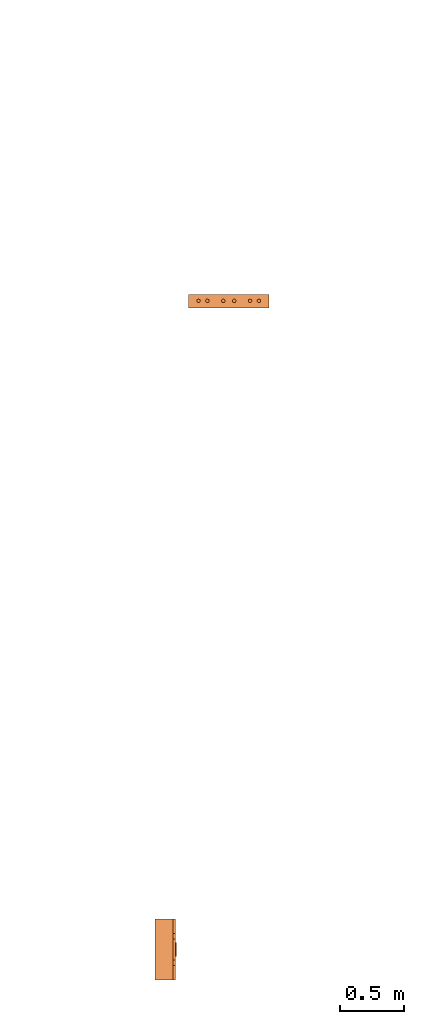
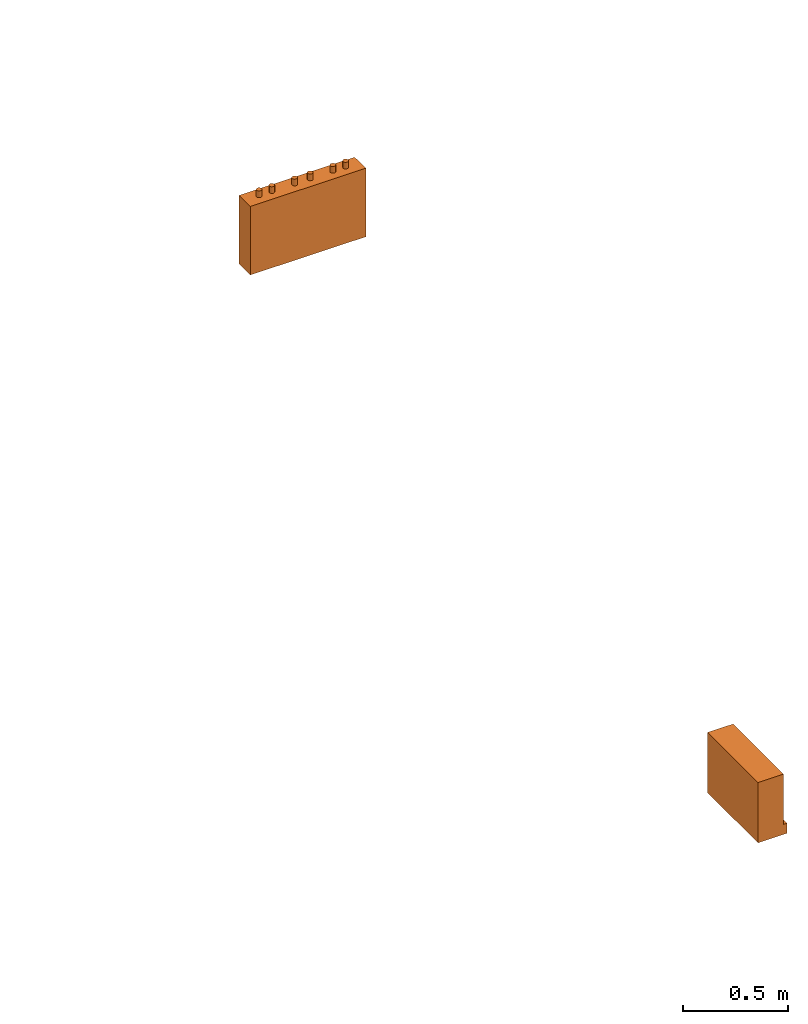
# One storey, part 2 of 4: 2 proxies.
"""IFC2X3 building model written with IfcOpenShell, lengths in millimetres."""

from ifc_helpers import new_model, entity, si_unit, converted_unit, derived_unit, direction, frame, origin, place, context, subcontext, project, spatial, faceted_brep, source, transform, mapped, material, material_list, type_object, type_shapes, element, save


model = new_model("IFC2X3")

# Units and contexts
model_context = context("Model", 3, precision=0.01, world=origin(), true_north=direction((6.12303176911189e-17, 1.0)))
body_context = subcontext(model_context, "Body", "Model", "MODEL_VIEW")
ifc_project = project(units=[si_unit("LENGTHUNIT", "METRE", prefix="MILLI"), si_unit("AREAUNIT", "SQUARE_METRE"), si_unit("VOLUMEUNIT", "CUBIC_METRE"), converted_unit("PLANEANGLEUNIT", "DEGREE", entity("IfcRatioMeasure", 0.0174532925199433), si_unit("PLANEANGLEUNIT", "RADIAN"), dimensions=[0, 0, 0, 0, 0, 0, 0]), si_unit("MASSUNIT", "GRAM", prefix="KILO"), derived_unit("MASSDENSITYUNIT", [(si_unit("MASSUNIT", "GRAM", prefix="KILO"), 1), (si_unit("LENGTHUNIT", "METRE"), -3)]), derived_unit("MOMENTOFINERTIAUNIT", [(si_unit("LENGTHUNIT", "METRE"), 4)]), si_unit("TIMEUNIT", "SECOND"), si_unit("FREQUENCYUNIT", "HERTZ"), si_unit("THERMODYNAMICTEMPERATUREUNIT", "DEGREE_CELSIUS"), derived_unit("THERMALTRANSMITTANCEUNIT", [(si_unit("MASSUNIT", "GRAM", prefix="KILO"), 1), (si_unit("THERMODYNAMICTEMPERATUREUNIT", "KELVIN"), -1), (si_unit("TIMEUNIT", "SECOND"), -3)]), derived_unit("VOLUMETRICFLOWRATEUNIT", [(si_unit("LENGTHUNIT", "METRE"), 3), (si_unit("TIMEUNIT", "SECOND"), -1)]), derived_unit("MASSFLOWRATEUNIT", [(si_unit("MASSUNIT", "GRAM", prefix="KILO"), 1), (si_unit("TIMEUNIT", "SECOND"), -1)]), derived_unit("ROTATIONALFREQUENCYUNIT", [(si_unit("TIMEUNIT", "SECOND"), -1)]), si_unit("ELECTRICCURRENTUNIT", "AMPERE"), si_unit("ELECTRICVOLTAGEUNIT", "VOLT"), si_unit("POWERUNIT", "WATT"), si_unit("FORCEUNIT", "NEWTON", prefix="KILO"), si_unit("ILLUMINANCEUNIT", "LUX"), si_unit("LUMINOUSFLUXUNIT", "LUMEN"), si_unit("LUMINOUSINTENSITYUNIT", "CANDELA"), derived_unit("USERDEFINED", [(si_unit("MASSUNIT", "GRAM", prefix="KILO"), -1), (si_unit("LENGTHUNIT", "METRE"), -2), (si_unit("TIMEUNIT", "SECOND"), 3), (si_unit("LUMINOUSFLUXUNIT", "LUMEN"), 1)]), derived_unit("LINEARVELOCITYUNIT", [(si_unit("LENGTHUNIT", "METRE"), 1), (si_unit("TIMEUNIT", "SECOND"), -1)]), si_unit("PRESSUREUNIT", "PASCAL"), derived_unit("USERDEFINED", [(si_unit("LENGTHUNIT", "METRE"), -2), (si_unit("MASSUNIT", "GRAM", prefix="KILO"), 1), (si_unit("TIMEUNIT", "SECOND"), -2)]), derived_unit("LINEARFORCEUNIT", [(si_unit("MASSUNIT", "GRAM", prefix="KILO"), 1), (si_unit("LENGTHUNIT", "METRE"), 1), (si_unit("TIMEUNIT", "SECOND"), -2), (si_unit("LENGTHUNIT", "METRE"), -1)]), derived_unit("PLANARFORCEUNIT", [(si_unit("MASSUNIT", "GRAM", prefix="KILO"), 1), (si_unit("LENGTHUNIT", "METRE"), 1), (si_unit("TIMEUNIT", "SECOND"), -2), (si_unit("LENGTHUNIT", "METRE"), -2)])], contexts=[model_context])

# Site, building, storey
site_placement = place(None, frame((0.0, 2493.83037508239, 0.0)))
site = spatial("IfcSite", under=ifc_project, at=site_placement, CompositionType="ELEMENT")
building_placement = place(site_placement, origin())
building = spatial("IfcBuilding", under=site, at=building_placement, CompositionType="ELEMENT")
storey_placement = place(building_placement, frame((0.0, 0.0, 15900.0)))
storey = spatial("IfcBuildingStorey", under=building, at=storey_placement, Name="05", CompositionType="ELEMENT", Elevation=15900.0)

# Proxies
ifc_material_1 = material()
ifc_material_2 = material()
ifc_material_list_1 = material_list([ifc_material_1, ifc_material_2])
building_element_proxy_type_1 = type_object("IfcBuildingElementProxyType", PredefinedType="NOTDEFINED", material=ifc_material_1)
shared_shape_1 = source(origin(), body_context, "Body", "Brep", [
    faceted_brep([(168.201612490282, 212.500000000001, 135.54049916809), (168.201612490282, 201.109127034741, 126.799974925206), (168.201612490282, 192.368602791857, 115.409101959946), (168.201612490282, 186.874079554102, 102.144149440585), (168.201612490282, 185.0, 87.9091019599461), (168.201612490282, 186.874079554102, 73.6740544793074), (168.201612490282, 192.368602791856, 60.4091019599461), (168.201612490282, 201.10912703474, 49.0182289946861), (168.201612490282, 212.500000000001, 40.2777047518019), (168.201612490282, 225.764952519362, 34.7831815140474), (168.201612490282, 240.0, 32.9091019599461), (168.201612490282, 254.235047480639, 34.7831815140472), (168.201612490282, 267.5, 40.2777047518019), (168.201612490282, 278.890872965261, 49.0182289946858), (168.201612490282, 287.631397208145, 60.4091019599458), (168.201612490282, 293.125920445899, 73.6740544793071), (168.201612490282, 295.0, 87.9091019599458), (168.201612490282, 293.125920445899, 102.144149440584), (168.201612490282, 287.631397208145, 115.409101959946), (168.201612490282, 278.890872965261, 126.799974925206), (168.201612490282, 267.500000000001, 135.54049916809), (168.201612490282, 254.235047480639, 141.035022405845), (168.201612490282, 240.0, 142.909101959946), (168.201612490282, 225.764952519362, 141.035022405845), (160.0, 225.764952519362, 34.7831815140474), (160.0, 212.500000000001, 40.2777047518019), (160.0, 201.10912703474, 49.0182289946861), (160.0, 192.368602791856, 60.4091019599461), (160.0, 186.874079554102, 73.6740544793074), (160.0, 185.0, 87.9091019599463), (160.0, 186.874079554102, 102.144149440585), (160.0, 192.368602791857, 115.409101959946), (160.0, 201.109127034741, 126.799974925206), (160.0, 212.500000000001, 135.54049916809), (160.0, 225.764952519362, 141.035022405845), (160.0, 240.0, 142.909101959946), (160.0, 254.235047480639, 141.035022405845), (160.0, 267.500000000001, 135.54049916809), (160.0, 278.890872965261, 126.799974925206), (160.0, 287.631397208145, 115.409101959946), (160.0, 293.125920445899, 102.144149440584), (160.0, 295.0, 87.9091019599458), (160.0, 293.125920445899, 73.6740544793071), (160.0, 287.631397208145, 60.4091019599458), (160.0, 278.890872965261, 49.0182289946858), (160.0, 267.5, 40.2777047518019), (160.0, 254.235047480639, 34.7831815140472), (160.0, 240.0, 32.9091019599461)], [[[0, 1, 2, 3, 4, 5, 6, 7, 8, 9, 10, 11, 12, 13, 14, 15, 16, 17, 18, 19, 20, 21, 22, 23]], [[24, 25, 26, 27, 28, 29, 30, 31, 32, 33, 34, 35, 36, 37, 38, 39, 40, 41, 42, 43, 44, 45, 46, 47]], [[40, 17, 16, 41]], [[39, 18, 17, 40]], [[20, 19, 38, 37]], [[39, 38, 19, 18]], [[21, 20, 37, 36]], [[22, 21, 36, 35]], [[34, 23, 22, 35]], [[33, 0, 23, 34]], [[2, 1, 32, 31]], [[33, 32, 1, 0]], [[3, 2, 31, 30]], [[4, 3, 30, 29]], [[28, 5, 4, 29]], [[27, 6, 5, 28]], [[8, 7, 26, 25]], [[27, 26, 7, 6]], [[9, 8, 25, 24]], [[10, 9, 24, 47]], [[46, 11, 10, 47]], [[45, 12, 11, 46]], [[14, 13, 44, 43]], [[45, 44, 13, 12]], [[15, 14, 43, 42]], [[16, 15, 42, 41]]]),
    faceted_brep([(160.0, 0.0, 0.0), (160.0, 480.0, 0.0), (160.0, 480.0, 58.2870579365997), (160.0, 365.0, 58.2870579366005), (160.0, 322.247482084292, 175.748635534839), (160.0, 157.75251791571, 175.748635534839), (160.0, 115.0, 58.2870579366), (160.0, 0.0, 58.2870579365997), (0.0, 480.0, 0.0), (0.0, 0.0, 0.0), (0.0, 0.0, 350.0), (0.0, 480.0, 350.0), (140.211167148102, 480.0, 350.0), (140.211167148102, 480.0, 58.2870579365997), (140.211167148102, 0.0, 350.0), (140.211167148102, 0.0, 58.2870579365997), (140.211167148102, 365.0, 58.2870579366), (140.211167148102, 115.0, 58.2870579366), (140.211167148102, 157.75251791571, 175.748635534839), (140.211167148102, 322.247482084292, 175.748635534839)], [[[0, 1, 2, 3, 4, 5, 6, 7]], [[8, 9, 10, 11]], [[8, 11, 12, 13, 2, 1]], [[11, 10, 14, 12]], [[10, 9, 0, 7, 15, 14]], [[1, 0, 9, 8]], [[16, 13, 12, 14, 15, 17, 18, 19]], [[13, 16, 3, 2]], [[17, 15, 7, 6]], [[18, 17, 6, 5]], [[19, 18, 5, 4]], [[16, 19, 4, 3]]]),
])
type_shapes(building_element_proxy_type_1, [shared_shape_1])
proxy_1_placement = place(storey_placement, frame((62632.608534949, 530.028144146123, 1500.0)))
element("IfcBuildingElementProxy", 1, at=proxy_1_placement, inside=storey, type_object=building_element_proxy_type_1, material=ifc_material_list_1, context=body_context, shape_type="MappedRepresentation", body=[
    mapped(shared_shape_1, transform((0.0, 0.0, 0.0), scale=1.0)),
])
ifc_material_3 = material()
ifc_material_list_2 = material_list([ifc_material_3, ifc_material_2])
building_element_proxy_type_2 = type_object("IfcBuildingElementProxyType", PredefinedType="NOTDEFINED", material=ifc_material_3)
shared_shape_2 = source(origin(), body_context, "Body", "Brep", [
    faceted_brep([(61.7366777047886, 89.258069163288, 398.0), (63.9615384211591, 86.3585742266764, 398.0), (65.3601443362239, 82.9820408581116, 398.0), (65.837182768177, 79.3585742266763, 398.0), (65.3601443362239, 75.735107595241, 398.0), (63.9615384211591, 72.3585742266763, 398.0), (61.7366777047886, 69.4590792900646, 398.0), (58.8371827681769, 67.2342185736942, 398.0), (55.4606493996122, 65.8356126586294, 398.0), (51.8371827681769, 65.3585742266764, 398.0), (48.2137161367416, 65.8356126586295, 398.0), (44.8371827681769, 67.2342185736943, 398.0), (41.9376878315653, 69.4590792900647, 398.0), (39.7128271151948, 72.3585742266764, 398.0), (38.31422120013, 75.7351075952411, 398.0), (37.837182768177, 79.3585742266764, 398.0), (38.31422120013, 82.9820408581117, 398.0), (39.7128271151949, 86.3585742266764, 398.0), (41.9376878315653, 89.258069163288, 398.0), (44.837182768177, 91.4829298796585, 398.0), (48.2137161367417, 92.8815357947233, 398.0), (51.837182768177, 93.3585742266764, 398.0), (55.4606493996123, 92.8815357947233, 398.0), (58.837182768177, 91.4829298796585, 398.0), (58.8371827681769, 67.2342185736942, 436.716690815491), (61.7366777047886, 69.4590792900646, 436.716690815491), (63.9615384211591, 72.3585742266763, 436.716690815491), (65.3601443362239, 75.735107595241, 436.716690815491), (65.837182768177, 79.3585742266764, 436.716690815491), (65.3601443362239, 82.9820408581116, 436.716690815491), (63.9615384211591, 86.3585742266764, 436.716690815491), (61.7366777047886, 89.258069163288, 436.716690815491), (58.837182768177, 91.4829298796585, 436.716690815491), (55.4606493996123, 92.8815357947233, 436.716690815491), (51.837182768177, 93.3585742266764, 436.716690815491), (48.2137161367417, 92.8815357947233, 436.716690815491), (44.837182768177, 91.4829298796585, 436.716690815491), (41.9376878315653, 89.258069163288, 436.716690815491), (39.7128271151949, 86.3585742266764, 436.716690815491), (38.31422120013, 82.9820408581117, 436.716690815491), (37.837182768177, 79.3585742266764, 436.716690815491), (38.31422120013, 75.7351075952411, 436.716690815491), (39.7128271151948, 72.3585742266764, 436.716690815491), (41.9376878315653, 69.4590792900647, 436.716690815491), (44.8371827681769, 67.2342185736943, 436.716690815491), (48.2137161367416, 65.8356126586295, 436.716690815491), (51.8371827681769, 65.3585742266764, 436.716690815491), (55.4606493996122, 65.8356126586294, 436.716690815491)], [[[0, 1, 2, 3, 4, 5, 6, 7, 8, 9, 10, 11, 12, 13, 14, 15, 16, 17, 18, 19, 20, 21, 22, 23]], [[24, 25, 26, 27, 28, 29, 30, 31, 32, 33, 34, 35, 36, 37, 38, 39, 40, 41, 42, 43, 44, 45, 46, 47]], [[40, 15, 14, 41]], [[13, 42, 41, 14]], [[43, 12, 11, 44]], [[13, 12, 43, 42]], [[44, 11, 10, 45]], [[9, 46, 45, 10]], [[47, 8, 7, 24]], [[6, 25, 24, 7]], [[26, 5, 4, 27]], [[6, 5, 26, 25]], [[27, 4, 3, 28]], [[47, 46, 9, 8]], [[1, 30, 29, 2]], [[0, 31, 30, 1]], [[22, 33, 32, 23]], [[23, 32, 31, 0]], [[21, 34, 33, 22]], [[28, 3, 2, 29]], [[35, 20, 19, 36]], [[18, 37, 36, 19]], [[38, 17, 16, 39]], [[18, 17, 38, 37]], [[39, 16, 15, 40]], [[35, 34, 21, 20]]]),
    faceted_brep([(58.837182768177, 542.517070120343, 436.716690815491), (61.7366777047886, 544.741930836713, 436.716690815491), (63.9615384211591, 547.641425773325, 436.716690815491), (65.360144336224, 551.017959141889, 436.716690815491), (65.837182768177, 554.641425773325, 436.716690815491), (65.360144336224, 558.26489240476, 436.716690815491), (63.9615384211592, 561.641425773325, 436.716690815491), (61.7366777047887, 564.540920709937, 436.716690815491), (58.8371827681771, 566.765781426307, 436.716690815491), (55.4606493996123, 568.164387341372, 436.716690815491), (51.8371827681771, 568.641425773325, 436.716690815491), (48.2137161367418, 568.164387341372, 436.716690815491), (44.8371827681771, 566.765781426307, 436.716690815491), (41.9376878315654, 564.540920709937, 436.716690815491), (39.7128271151949, 561.641425773325, 436.716690815491), (38.3142212001301, 558.26489240476, 436.716690815491), (37.837182768177, 554.641425773325, 436.716690815491), (38.3142212001301, 551.01795914189, 436.716690815491), (39.7128271151949, 547.641425773325, 436.716690815491), (41.9376878315653, 544.741930836713, 436.716690815491), (44.837182768177, 542.517070120343, 436.716690815491), (48.2137161367417, 541.118464205278, 436.716690815491), (51.837182768177, 540.641425773325, 436.716690815491), (55.4606493996123, 541.118464205278, 436.716690815491), (51.8371827681771, 568.641425773325, 398.0), (55.4606493996123, 568.164387341372, 398.0), (58.8371827681771, 566.765781426307, 398.0), (61.7366777047887, 564.540920709937, 398.0), (63.9615384211592, 561.641425773325, 398.0), (65.360144336224, 558.26489240476, 398.0), (65.837182768177, 554.641425773325, 398.0), (65.360144336224, 551.017959141889, 398.0), (63.9615384211591, 547.641425773325, 398.0), (61.7366777047886, 544.741930836713, 398.0), (58.837182768177, 542.517070120343, 398.0), (55.4606493996123, 541.118464205278, 398.0), (51.837182768177, 540.641425773325, 398.0), (48.2137161367417, 541.118464205278, 398.0), (44.837182768177, 542.517070120343, 398.0), (41.9376878315653, 544.741930836713, 398.0), (39.7128271151949, 547.641425773325, 398.0), (38.3142212001301, 551.01795914189, 398.0), (37.837182768177, 554.641425773325, 398.0), (38.3142212001301, 558.26489240476, 398.0), (39.7128271151949, 561.641425773325, 398.0), (41.9376878315654, 564.540920709937, 398.0), (44.8371827681771, 566.765781426307, 398.0), (48.2137161367418, 568.164387341372, 398.0)], [[[0, 1, 2, 3, 4, 5, 6, 7, 8, 9, 10, 11, 12, 13, 14, 15, 16, 17, 18, 19, 20, 21, 22, 23]], [[24, 25, 26, 27, 28, 29, 30, 31, 32, 33, 34, 35, 36, 37, 38, 39, 40, 41, 42, 43, 44, 45, 46, 47]], [[17, 41, 40, 18]], [[39, 19, 18, 40]], [[20, 38, 37, 21]], [[39, 38, 20, 19]], [[21, 37, 36, 22]], [[41, 17, 16, 42]], [[23, 35, 34, 0]], [[33, 1, 0, 34]], [[2, 32, 31, 3]], [[33, 32, 2, 1]], [[3, 31, 30, 4]], [[35, 23, 22, 36]], [[29, 5, 4, 30]], [[28, 6, 5, 29]], [[9, 25, 24, 10]], [[27, 7, 6, 28]], [[26, 8, 7, 27]], [[26, 25, 9, 8]], [[11, 47, 46, 12]], [[45, 13, 12, 46]], [[14, 44, 43, 15]], [[45, 44, 14, 13]], [[15, 43, 42, 16]], [[47, 11, 10, 24]]]),
    faceted_brep([(58.8371827681769, 472.517070120343, 436.716690815491), (61.7366777047886, 474.741930836713, 436.716690815491), (63.961538421159, 477.641425773325, 436.716690815491), (65.3601443362239, 481.017959141889, 436.716690815491), (65.8371827681769, 484.641425773325, 436.716690815491), (65.3601443362239, 488.26489240476, 436.716690815491), (63.9615384211591, 491.641425773325, 436.716690815491), (61.7366777047886, 494.540920709936, 436.716690815491), (58.837182768177, 496.765781426307, 436.716690815491), (55.4606493996123, 498.164387341372, 436.716690815491), (51.837182768177, 498.641425773325, 436.716690815491), (48.2137161367417, 498.164387341372, 436.716690815491), (44.837182768177, 496.765781426307, 436.716690815491), (41.9376878315653, 494.540920709937, 436.716690815491), (39.7128271151948, 491.641425773325, 436.716690815491), (38.31422120013, 488.26489240476, 436.716690815491), (37.837182768177, 484.641425773325, 436.716690815491), (38.31422120013, 481.01795914189, 436.716690815491), (39.7128271151948, 477.641425773325, 436.716690815491), (41.9376878315653, 474.741930836713, 436.716690815491), (44.8371827681769, 472.517070120343, 436.716690815491), (48.2137161367416, 471.118464205278, 436.716690815491), (51.8371827681769, 470.641425773325, 436.716690815491), (55.4606493996122, 471.118464205278, 436.716690815491), (51.837182768177, 498.641425773325, 398.0), (55.4606493996123, 498.164387341372, 398.0), (58.837182768177, 496.765781426307, 398.0), (61.7366777047886, 494.540920709936, 398.0), (63.9615384211591, 491.641425773325, 398.0), (65.3601443362239, 488.26489240476, 398.0), (65.8371827681769, 484.641425773325, 398.0), (65.3601443362239, 481.017959141889, 398.0), (63.961538421159, 477.641425773325, 398.0), (61.7366777047886, 474.741930836713, 398.0), (58.8371827681769, 472.517070120343, 398.0), (55.4606493996122, 471.118464205278, 398.0), (51.8371827681769, 470.641425773325, 398.0), (48.2137161367416, 471.118464205278, 398.0), (44.8371827681769, 472.517070120343, 398.0), (41.9376878315653, 474.741930836713, 398.0), (39.7128271151948, 477.641425773325, 398.0), (38.31422120013, 481.01795914189, 398.0), (37.837182768177, 484.641425773325, 398.0), (38.31422120013, 488.26489240476, 398.0), (39.7128271151948, 491.641425773325, 398.0), (41.9376878315653, 494.540920709937, 398.0), (44.837182768177, 496.765781426307, 398.0), (48.2137161367417, 498.164387341372, 398.0)], [[[0, 1, 2, 3, 4, 5, 6, 7, 8, 9, 10, 11, 12, 13, 14, 15, 16, 17, 18, 19, 20, 21, 22, 23]], [[24, 25, 26, 27, 28, 29, 30, 31, 32, 33, 34, 35, 36, 37, 38, 39, 40, 41, 42, 43, 44, 45, 46, 47]], [[16, 42, 41, 17]], [[40, 18, 17, 41]], [[19, 39, 38, 20]], [[40, 39, 19, 18]], [[20, 38, 37, 21]], [[36, 22, 21, 37]], [[23, 35, 34, 0]], [[33, 1, 0, 34]], [[2, 32, 31, 3]], [[33, 32, 2, 1]], [[3, 31, 30, 4]], [[23, 22, 36, 35]], [[28, 6, 5, 29]], [[27, 7, 6, 28]], [[25, 9, 8, 26]], [[26, 8, 7, 27]], [[24, 10, 9, 25]], [[4, 30, 29, 5]], [[11, 47, 46, 12]], [[45, 13, 12, 46]], [[14, 44, 43, 15]], [[45, 44, 14, 13]], [[15, 43, 42, 16]], [[11, 10, 24, 47]]]),
    faceted_brep([(58.8371827681766, 347.517070120343, 436.716690815491), (61.7366777047883, 349.741930836713, 436.716690815491), (63.9615384211588, 352.641425773325, 436.716690815491), (65.3601443362236, 356.017959141889, 436.716690815491), (65.8371827681767, 359.641425773325, 436.716690815491), (65.3601443362237, 363.26489240476, 436.716690815491), (63.9615384211589, 366.641425773325, 436.716690815491), (61.7366777047884, 369.540920709937, 436.716690815491), (58.8371827681767, 371.765781426307, 436.716690815491), (55.460649399612, 373.164387341372, 436.716690815491), (51.8371827681767, 373.641425773325, 436.716690815491), (48.2137161367414, 373.164387341372, 436.716690815491), (44.8371827681767, 371.765781426307, 436.716690815491), (41.9376878315651, 369.540920709937, 436.716690815491), (39.7128271151946, 366.641425773325, 436.716690815491), (38.3142212001298, 363.26489240476, 436.716690815491), (37.8371827681767, 359.641425773325, 436.716690815491), (38.3142212001298, 356.01795914189, 436.716690815491), (39.7128271151945, 352.641425773325, 436.716690815491), (41.937687831565, 349.741930836713, 436.716690815491), (44.8371827681767, 347.517070120343, 436.716690815491), (48.2137161367414, 346.118464205278, 436.716690815491), (51.8371827681766, 345.641425773325, 436.716690815491), (55.4606493996119, 346.118464205278, 436.716690815491), (51.8371827681767, 373.641425773325, 398.0), (55.460649399612, 373.164387341372, 398.0), (58.8371827681767, 371.765781426307, 398.0), (61.7366777047884, 369.540920709937, 398.0), (63.9615384211589, 366.641425773325, 398.0), (65.3601443362237, 363.26489240476, 398.0), (65.8371827681767, 359.641425773325, 398.0), (65.3601443362236, 356.017959141889, 398.0), (63.9615384211588, 352.641425773325, 398.0), (61.7366777047883, 349.741930836713, 398.0), (58.8371827681766, 347.517070120343, 398.0), (55.4606493996119, 346.118464205278, 398.0), (51.8371827681766, 345.641425773325, 398.0), (48.2137161367414, 346.118464205278, 398.0), (44.8371827681767, 347.517070120343, 398.0), (41.937687831565, 349.741930836713, 398.0), (39.7128271151945, 352.641425773325, 398.0), (38.3142212001298, 356.01795914189, 398.0), (37.8371827681767, 359.641425773325, 398.0), (38.3142212001298, 363.26489240476, 398.0), (39.7128271151946, 366.641425773325, 398.0), (41.9376878315651, 369.540920709937, 398.0), (44.8371827681767, 371.765781426307, 398.0), (48.2137161367414, 373.164387341372, 398.0)], [[[0, 1, 2, 3, 4, 5, 6, 7, 8, 9, 10, 11, 12, 13, 14, 15, 16, 17, 18, 19, 20, 21, 22, 23]], [[24, 25, 26, 27, 28, 29, 30, 31, 32, 33, 34, 35, 36, 37, 38, 39, 40, 41, 42, 43, 44, 45, 46, 47]], [[16, 42, 41, 17]], [[40, 18, 17, 41]], [[19, 39, 38, 20]], [[40, 39, 19, 18]], [[20, 38, 37, 21]], [[36, 22, 21, 37]], [[23, 35, 34, 0]], [[33, 1, 0, 34]], [[2, 32, 31, 3]], [[33, 32, 2, 1]], [[3, 31, 30, 4]], [[23, 22, 36, 35]], [[28, 6, 5, 29]], [[27, 7, 6, 28]], [[25, 9, 8, 26]], [[26, 8, 7, 27]], [[24, 10, 9, 25]], [[4, 30, 29, 5]], [[11, 47, 46, 12]], [[45, 13, 12, 46]], [[14, 44, 43, 15]], [[45, 44, 14, 13]], [[15, 43, 42, 16]], [[11, 10, 24, 47]]]),
    faceted_brep([(58.8371827681766, 262.234218573694, 436.716690815491), (61.7366777047883, 264.459079290065, 436.716690815491), (63.9615384211588, 267.358574226676, 436.716690815491), (65.3601443362236, 270.735107595241, 436.716690815491), (65.8371827681767, 274.358574226676, 436.716690815491), (65.3601443362237, 277.982040858112, 436.716690815491), (63.9615384211588, 281.358574226676, 436.716690815491), (61.7366777047884, 284.258069163288, 436.716690815491), (58.8371827681767, 286.482929879658, 436.716690815491), (55.460649399612, 287.881535794723, 436.716690815491), (51.8371827681767, 288.358574226676, 436.716690815491), (48.2137161367414, 287.881535794723, 436.716690815491), (44.8371827681767, 286.482929879659, 436.716690815491), (41.9376878315651, 284.258069163288, 436.716690815491), (39.7128271151946, 281.358574226676, 436.716690815491), (38.3142212001298, 277.982040858112, 436.716690815491), (37.8371827681767, 274.358574226676, 436.716690815491), (38.3142212001297, 270.735107595241, 436.716690815491), (39.7128271151945, 267.358574226676, 436.716690815491), (41.937687831565, 264.459079290065, 436.716690815491), (44.8371827681767, 262.234218573694, 436.716690815491), (48.2137161367414, 260.835612658629, 436.716690815491), (51.8371827681766, 260.358574226676, 436.716690815491), (55.4606493996119, 260.835612658629, 436.716690815491), (51.8371827681767, 288.358574226676, 398.0), (55.460649399612, 287.881535794723, 398.0), (58.8371827681767, 286.482929879658, 398.0), (61.7366777047884, 284.258069163288, 398.0), (63.9615384211588, 281.358574226676, 398.0), (65.3601443362237, 277.982040858112, 398.0), (65.8371827681767, 274.358574226676, 398.0), (65.3601443362236, 270.735107595241, 398.0), (63.9615384211588, 267.358574226676, 398.0), (61.7366777047883, 264.459079290065, 398.0), (58.8371827681766, 262.234218573694, 398.0), (55.4606493996119, 260.835612658629, 398.0), (51.8371827681766, 260.358574226676, 398.0), (48.2137161367414, 260.835612658629, 398.0), (44.8371827681767, 262.234218573694, 398.0), (41.937687831565, 264.459079290065, 398.0), (39.7128271151945, 267.358574226676, 398.0), (38.3142212001297, 270.735107595241, 398.0), (37.8371827681767, 274.358574226676, 398.0), (38.3142212001298, 277.982040858112, 398.0), (39.7128271151946, 281.358574226676, 398.0), (41.9376878315651, 284.258069163288, 398.0), (44.8371827681767, 286.482929879659, 398.0), (48.2137161367414, 287.881535794723, 398.0)], [[[0, 1, 2, 3, 4, 5, 6, 7, 8, 9, 10, 11, 12, 13, 14, 15, 16, 17, 18, 19, 20, 21, 22, 23]], [[24, 25, 26, 27, 28, 29, 30, 31, 32, 33, 34, 35, 36, 37, 38, 39, 40, 41, 42, 43, 44, 45, 46, 47]], [[16, 42, 41, 17]], [[40, 18, 17, 41]], [[19, 39, 38, 20]], [[40, 39, 19, 18]], [[20, 38, 37, 21]], [[36, 22, 21, 37]], [[23, 35, 34, 0]], [[33, 1, 0, 34]], [[2, 32, 31, 3]], [[33, 32, 2, 1]], [[3, 31, 30, 4]], [[23, 22, 36, 35]], [[4, 30, 29, 5]], [[28, 6, 5, 29]], [[7, 27, 26, 8]], [[28, 27, 7, 6]], [[8, 26, 25, 9]], [[24, 10, 9, 25]], [[11, 47, 46, 12]], [[45, 13, 12, 46]], [[14, 44, 43, 15]], [[45, 44, 14, 13]], [[15, 43, 42, 16]], [[11, 10, 24, 47]]]),
    faceted_brep([(58.8371827681768, 137.234218573694, 436.716690815491), (61.7366777047885, 139.459079290065, 436.716690815491), (63.961538421159, 142.358574226676, 436.716690815491), (65.3601443362238, 145.735107595241, 436.716690815491), (65.8371827681769, 149.358574226676, 436.716690815491), (65.3601443362239, 152.982040858112, 436.716690815491), (63.961538421159, 156.358574226676, 436.716690815491), (61.7366777047886, 159.258069163288, 436.716690815491), (58.8371827681769, 161.482929879659, 436.716690815491), (55.4606493996122, 162.881535794723, 436.716690815491), (51.8371827681769, 163.358574226676, 436.716690815491), (48.2137161367416, 162.881535794723, 436.716690815491), (44.8371827681769, 161.482929879659, 436.716690815491), (41.9376878315653, 159.258069163288, 436.716690815491), (39.7128271151948, 156.358574226676, 436.716690815491), (38.31422120013, 152.982040858112, 436.716690815491), (37.8371827681769, 149.358574226676, 436.716690815491), (38.3142212001299, 145.735107595241, 436.716690815491), (39.7128271151947, 142.358574226676, 436.716690815491), (41.9376878315652, 139.459079290065, 436.716690815491), (44.8371827681769, 137.234218573694, 436.716690815491), (48.2137161367416, 135.83561265863, 436.716690815491), (51.8371827681768, 135.358574226676, 436.716690815491), (55.4606493996121, 135.835612658629, 436.716690815491), (61.7366777047886, 159.258069163288, 398.0), (63.961538421159, 156.358574226676, 398.0), (65.3601443362239, 152.982040858112, 398.0), (65.8371827681769, 149.358574226676, 398.0), (65.3601443362238, 145.735107595241, 398.0), (63.961538421159, 142.358574226676, 398.0), (61.7366777047885, 139.459079290065, 398.0), (58.8371827681768, 137.234218573694, 398.0), (55.4606493996121, 135.835612658629, 398.0), (51.8371827681768, 135.358574226676, 398.0), (48.2137161367416, 135.83561265863, 398.0), (44.8371827681769, 137.234218573694, 398.0), (41.9376878315652, 139.459079290065, 398.0), (39.7128271151947, 142.358574226676, 398.0), (38.3142212001299, 145.735107595241, 398.0), (37.8371827681769, 149.358574226676, 398.0), (38.31422120013, 152.982040858112, 398.0), (39.7128271151948, 156.358574226676, 398.0), (41.9376878315653, 159.258069163288, 398.0), (44.8371827681769, 161.482929879659, 398.0), (48.2137161367416, 162.881535794723, 398.0), (51.8371827681769, 163.358574226676, 398.0), (55.4606493996122, 162.881535794723, 398.0), (58.8371827681769, 161.482929879659, 398.0)], [[[0, 1, 2, 3, 4, 5, 6, 7, 8, 9, 10, 11, 12, 13, 14, 15, 16, 17, 18, 19, 20, 21, 22, 23]], [[24, 25, 26, 27, 28, 29, 30, 31, 32, 33, 34, 35, 36, 37, 38, 39, 40, 41, 42, 43, 44, 45, 46, 47]], [[16, 39, 38, 17]], [[37, 18, 17, 38]], [[19, 36, 35, 20]], [[37, 36, 19, 18]], [[20, 35, 34, 21]], [[33, 22, 21, 34]], [[23, 32, 31, 0]], [[30, 1, 0, 31]], [[2, 29, 28, 3]], [[30, 29, 2, 1]], [[3, 28, 27, 4]], [[23, 22, 33, 32]], [[25, 6, 5, 26]], [[24, 7, 6, 25]], [[46, 9, 8, 47]], [[47, 8, 7, 24]], [[45, 10, 9, 46]], [[4, 27, 26, 5]], [[11, 44, 43, 12]], [[42, 13, 12, 43]], [[14, 41, 40, 15]], [[42, 41, 14, 13]], [[15, 40, 39, 16]], [[11, 10, 45, 44]]]),
    faceted_brep([(106.0, 0.0, 0.0), (106.0, 634.0, 0.0), (106.0, 634.0, 398.0), (106.0, 0.0, 398.0), (0.0, 634.0, 398.0), (0.0, 524.500000000001, 254.822902819641), (0.0, 518.470476127564, 257.320413382257), (0.0, 529.677669529664, 250.849937254693), (0.0, 512.0, 258.17226772503), (0.0, 122.0, 258.17226772503), (0.0, 533.650635094612, 245.672267725029), (0.0, 536.148145657227, 239.642743852593), (0.0, 537.0, 233.17226772503), (0.0, 634.0, 0.0), (0.0, 0.0, 398.0), (0.0, 537.0, 143.17226772503), (0.0, 536.148145657227, 136.701791597467), (0.0, 533.650635094611, 130.67226772503), (0.0, 529.677669529664, 125.494598195366), (0.0, 524.5, 121.521632630419), (0.0, 518.470476127563, 119.024122067803), (0.0, 512.0, 118.17226772503), (0.0, 122.0, 118.172267725031), (0.0, 0.0, 0.0), (0.0, 97.0, 233.17226772503), (0.0, 115.529523872437, 119.024122067805), (0.0, 109.5, 121.521632630421), (0.0, 104.322330470337, 125.494598195368), (0.0, 100.349364905389, 130.672267725032), (0.0, 97.8518543427736, 136.701791597469), (0.0, 97.0, 143.172267725033), (0.0, 97.8518543427739, 239.642743852593), (0.0, 115.529523872438, 257.320413382257), (0.0, 109.500000000001, 254.822902819641), (0.0, 104.322330470337, 250.849937254693), (0.0, 100.34936490539, 245.67226772503), (16.2395209800454, 533.650635094612, 245.672267725029), (16.2395209800454, 536.148145657227, 239.642743852593), (16.2395209800454, 537.0, 233.17226772503), (16.2395209800454, 537.0, 143.17226772503), (16.2395209800454, 536.148145657227, 136.701791597467), (16.2395209800454, 533.650635094611, 130.67226772503), (16.2395209800454, 529.677669529664, 125.494598195366), (16.2395209800454, 524.5, 121.521632630419), (16.2395209800454, 518.470476127563, 119.024122067803), (16.2395209800454, 512.0, 118.17226772503), (16.2395209800454, 122.0, 118.172267725032), (16.2395209800454, 115.529523872437, 119.024122067805), (16.2395209800454, 109.5, 121.521632630421), (16.2395209800454, 104.322330470337, 125.494598195368), (16.2395209800454, 100.349364905389, 130.672267725032), (16.2395209800454, 97.8518543427736, 136.701791597469), (16.2395209800454, 97.0, 143.172267725032), (16.2395209800454, 97.0, 233.17226772503), (16.2395209800454, 97.8518543427739, 239.642743852593), (16.2395209800454, 100.34936490539, 245.67226772503), (16.2395209800454, 104.322330470337, 250.849937254694), (16.2395209800454, 109.500000000001, 254.822902819641), (16.2395209800454, 115.529523872438, 257.320413382257), (16.2395209800454, 122.0, 258.17226772503), (16.2395209800454, 512.0, 258.17226772503), (16.2395209800454, 518.470476127564, 257.320413382257), (16.2395209800454, 524.500000000001, 254.822902819641), (16.2395209800454, 529.677669529664, 250.849937254693)], [[[0, 1, 2, 3]], [[4, 5, 6]], [[5, 4, 7]], [[6, 8, 4]], [[4, 8, 9]], [[10, 7, 4]], [[11, 10, 4]], [[12, 11, 4]], [[4, 13, 12]], [[9, 14, 4]], [[15, 12, 13]], [[16, 15, 13]], [[16, 13, 17]], [[18, 17, 13]], [[13, 19, 18]], [[19, 13, 20]], [[21, 20, 13]], [[13, 22, 21]], [[22, 13, 23]], [[14, 24, 23]], [[25, 22, 23]], [[23, 26, 25]], [[26, 23, 27]], [[28, 27, 23]], [[28, 23, 29]], [[30, 29, 23]], [[30, 23, 24]], [[31, 24, 14]], [[9, 32, 14]], [[33, 14, 32]], [[14, 33, 34]], [[34, 35, 14]], [[35, 31, 14]], [[2, 1, 13, 4]], [[3, 2, 4, 14]], [[0, 3, 14, 23]], [[1, 0, 23, 13]], [[36, 37, 38, 39, 40, 41, 42, 43, 44, 45, 46, 47, 48, 49, 50, 51, 52, 53, 54, 55, 56, 57, 58, 59, 60, 61, 62, 63]], [[9, 8, 60, 59]], [[32, 9, 59, 58]], [[33, 32, 58, 57]], [[33, 57, 56, 34]], [[35, 34, 56, 55]], [[31, 35, 55, 54]], [[31, 54, 53, 24]], [[24, 53, 52, 30]], [[29, 30, 52, 51]], [[28, 29, 51, 50]], [[28, 50, 49, 27]], [[26, 27, 49, 48]], [[25, 26, 48, 47]], [[25, 47, 46, 22]], [[22, 46, 45, 21]], [[20, 21, 45, 44]], [[19, 20, 44, 43]], [[19, 43, 42, 18]], [[17, 18, 42, 41]], [[16, 17, 41, 40]], [[16, 40, 39, 15]], [[15, 39, 38, 12]], [[11, 12, 38, 37]], [[10, 11, 37, 36]], [[10, 36, 63, 7]], [[5, 7, 63, 62]], [[6, 5, 62, 61]], [[6, 61, 60, 8]]]),
])
type_shapes(building_element_proxy_type_2, [shared_shape_2])
proxy_2_placement = place(storey_placement, frame((62895.8678256518, 5920.91905726716, 1500.0), z_axis=(0.0, 0.0, 1.0), x_axis=(0.0, -1.0, 0.0)))
element("IfcBuildingElementProxy", 2, at=proxy_2_placement, inside=storey, type_object=building_element_proxy_type_2, material=ifc_material_list_2, context=body_context, shape_type="MappedRepresentation", body=[
    mapped(shared_shape_2, transform((0.0, 0.0, 0.0), scale=1.0)),
])

save(model, "model.ifc")
